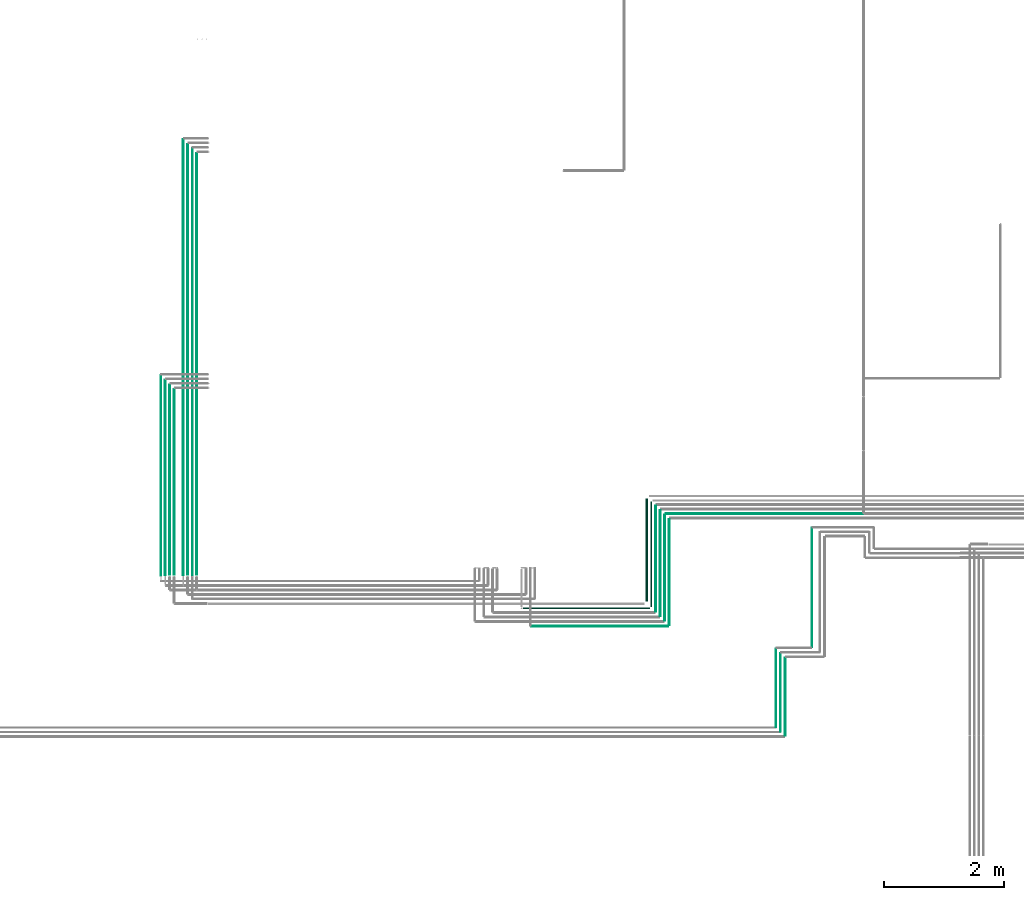
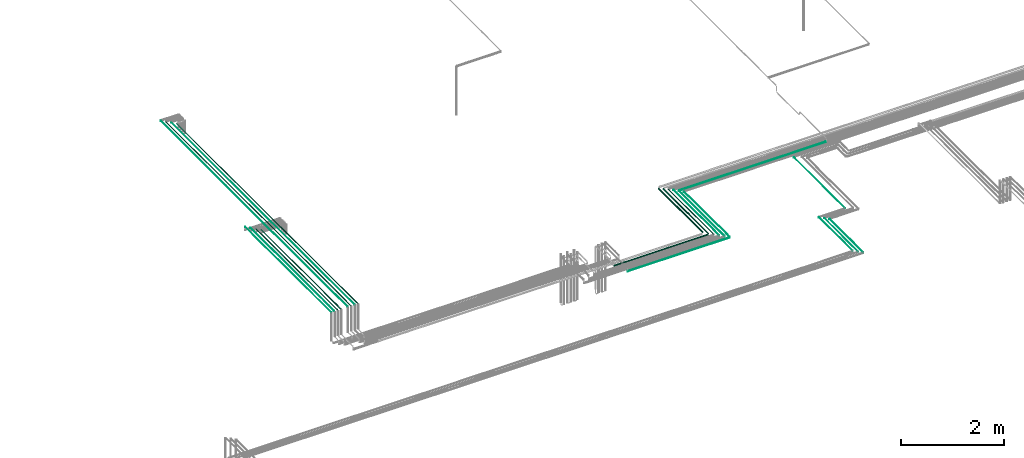
# One storey, part 5 of 65: 21 flow segments.
"""IFC2X3 building model written with IfcOpenShell, lengths in millimetres."""

import ifcopenshell
import ifcopenshell.guid

model = None  # the IFC model being written
_history = None  # IfcOwnerHistory: only IFC2X3 demands one
_inside = {}  # id of a spatial element -> (the spatial element, [elements in it])
_under = {}  # id of a project, library or spatial element -> (it, [spatial elements below it])
_declared = {}  # id of a project -> (the project, [libraries it declares])
_typed = {}  # id of a type object -> (the type object, [elements of that type])
_made_of = {}  # id of a material, layer set ... -> (it, [elements and type objects made of it])


def new_model(schema):
    """Start an empty IFC model of exactly this schema.

    Asked for "IFC4X3", IfcOpenShell would pick the latest addendum, in which some entities
    have other attributes; the version numbers below select the first issue.
    IFC2X3 requires an IfcOwnerHistory on every rooted entity: one is made here for all.
    """
    global model, _history
    if schema == "IFC4X3":
        model = ifcopenshell.file(schema_version=(4, 3, 0, 0))
    else:
        model = ifcopenshell.file(schema=schema)
    _inside.clear()
    _under.clear()
    _declared.clear()
    _typed.clear()
    _made_of.clear()
    _history = None
    if model.schema == "IFC2X3":
        org = make("IfcOrganization", Name="unknown")
        user = make(
            "IfcPersonAndOrganization",
            ThePerson=make("IfcPerson", FamilyName="unknown"),
            TheOrganization=org,
        )
        app = make(
            "IfcApplication",
            ApplicationDeveloper=org,
            Version="unknown",
            ApplicationFullName="unknown",
            ApplicationIdentifier="unknown",
        )
        _history = make(
            "IfcOwnerHistory",
            OwningUser=user,
            OwningApplication=app,
            ChangeAction="ADDED",
            CreationDate=0,
        )
    return model


def make(cls, **values):
    """One entity of the class cls with the attributes given. An attribute that is None is left unset."""
    return model.create_entity(
        cls, **{name: value for name, value in values.items() if value is not None}
    )


def entity(cls, *values):
    """Any entity or typed value of the class cls, its attributes in the order of the schema. None: left unset."""
    e = model.create_entity(cls)
    for i, value in enumerate(values):
        if value is not None:
            e[i] = value
    return e


def rooted(cls, **values):
    """An entity with a GlobalId (a new one), such as an element, a storey or a relation."""
    return make(cls, GlobalId=ifcopenshell.guid.new(), OwnerHistory=_history, **values)


def si_unit(unit_type, name, prefix=None):
    """IfcSIUnit, for example si_unit("LENGTHUNIT", "METRE", prefix="MILLI")."""
    return make("IfcSIUnit", UnitType=unit_type, Prefix=prefix, Name=name)


def converted_unit(unit_type, name, factor, base, dimensions=None, offset=None):
    """IfcConversionBasedUnit, such as the inch: factor (a typed value) times the base unit."""
    return make(
        "IfcConversionBasedUnit"
        if offset is None
        else "IfcConversionBasedUnitWithOffset",
        ConversionOffset=offset,
        Dimensions=None
        if dimensions is None
        else entity("IfcDimensionalExponents", *dimensions),
        UnitType=unit_type,
        Name=name,
        ConversionFactor=make(
            "IfcMeasureWithUnit", ValueComponent=factor, UnitComponent=base
        ),
    )


def derived_unit(unit_type, elements):
    """IfcDerivedUnit: a product of units, each with its exponent."""
    return make(
        "IfcDerivedUnit",
        Elements=[
            make("IfcDerivedUnitElement", Unit=unit, Exponent=power)
            for unit, power in elements
        ],
        UnitType=unit_type,
    )


def assignment(units):
    """IfcUnitAssignment: the units of a project."""
    return None if units is None else make("IfcUnitAssignment", Units=units)


def point(xyz):
    """IfcCartesianPoint."""
    return None if xyz is None else make("IfcCartesianPoint", Coordinates=xyz)


def direction(xyz):
    """IfcDirection."""
    return None if xyz is None else make("IfcDirection", DirectionRatios=xyz)


def frame(location, z_axis=None, x_axis=None):
    """IfcAxis2Placement3D, a coordinate frame: its origin and axes. An axis left out is left unset."""
    return make(
        "IfcAxis2Placement3D",
        Location=point(location),
        Axis=direction(z_axis),
        RefDirection=direction(x_axis),
    )


def frame_2d(location, x_axis=None):
    """IfcAxis2Placement2D, a coordinate frame in the plane: its origin and x axis."""
    return make(
        "IfcAxis2Placement2D", Location=point(location), RefDirection=direction(x_axis)
    )


def origin():
    """The frame at (0, 0, 0) with its axes left unset."""
    return frame((0.0, 0.0, 0.0))


def origin_2d_with_axis():
    """The frame at (0, 0) in the plane with the x axis (1, 0) written out."""
    return frame_2d((0.0, 0.0), x_axis=(1.0, 0.0))


def place(relative_to, where):
    """IfcLocalPlacement: puts the frame where relative to a parent placement (None: the world)."""
    return make(
        "IfcLocalPlacement", PlacementRelTo=relative_to, RelativePlacement=where
    )


def context(
    kind, dimensions, precision=None, world=None, true_north=None, identifier=None
):
    """IfcGeometricRepresentationContext, for example the 3D "Model" context."""
    return make(
        "IfcGeometricRepresentationContext",
        ContextIdentifier=identifier,
        ContextType=kind,
        CoordinateSpaceDimension=dimensions,
        Precision=precision,
        WorldCoordinateSystem=world,
        TrueNorth=true_north,
    )


def subcontext(parent, identifier, kind, view, scale=None):
    """IfcGeometricRepresentationSubContext, for example "Body" below "Model"."""
    return make(
        "IfcGeometricRepresentationSubContext",
        ContextIdentifier=identifier,
        ContextType=kind,
        ParentContext=parent,
        TargetScale=scale,
        TargetView=view,
    )


def project(units=None, contexts=None):
    """IfcProject with its units and contexts."""
    return rooted(
        "IfcProject",
        Name="project",
        RepresentationContexts=contexts,
        UnitsInContext=assignment(units),
    )


def spatial(cls, under=None, at=None, **own):
    """A site, building, storey or space (cls), placed at a placement, below another one or the project."""
    s = rooted(cls, ObjectPlacement=at, **own)
    if under is not None:
        _under.setdefault(under.id(), (under, []))[1].append(s)
    return s


def profile(cls, at=None, kind="AREA", **sizes):
    """A parametric profile (cls). Its sizes go by their IFC names, for example OverallWidth=200.0."""
    return make(cls, ProfileType=kind, Position=at, **sizes)


def circle(**sizes):
    """IfcCircleProfileDef."""
    return profile("IfcCircleProfileDef", **sizes)


def extrude(swept, where, along, depth):
    """IfcExtrudedAreaSolid: the profile swept, set in the frame where, extruded along a direction by depth."""
    return make(
        "IfcExtrudedAreaSolid",
        SweptArea=swept,
        Position=where,
        ExtrudedDirection=direction(along),
        Depth=depth,
    )


def shape(context_of_items, identifier, shape_type, items):
    """IfcShapeRepresentation: the items that make up one representation, for example the "Body"."""
    return make(
        "IfcShapeRepresentation",
        ContextOfItems=context_of_items,
        RepresentationIdentifier=identifier,
        RepresentationType=shape_type,
        Items=items,
    )


def made_of(thing, what):
    """Note that an element or type object is made of a material, layer set ...; save() writes the relation."""
    if what is not None:
        _made_of.setdefault(what.id(), (what, []))[1].append(thing)
    return thing


def type_object(cls, material=None, **own):
    """A type object (cls), such as IfcWallType, which elements share."""
    return made_of(rooted(cls, **own), material)


def element(
    cls,
    number,
    at=None,
    inside=None,
    cuts=None,
    type_object=None,
    material=None,
    context=None,
    identifier="Body",
    shape_type=None,
    held_by="IfcProductDefinitionShape",
    body=None,
    shapes=None,
    **own,
):
    """One element of the class cls, such as IfcWall. Its Tag is "e" and its number.

    at: its placement. inside: the storey or other place that contains it. cuts: it is an
    opening in that element (IfcRelVoidsElement). A single representation is given by context,
    identifier, shape_type and body (its items); several are given by shapes. held_by: the class
    of the entity that holds the representations. save() writes the other relations.
    """
    e = rooted(cls, Tag="e%d" % number, ObjectPlacement=at, **own)
    if body is not None:
        shapes = [shape(context, identifier, shape_type, body)]
    if shapes is not None:
        e.Representation = make(held_by, Representations=shapes)
    if inside is not None:
        _inside.setdefault(inside.id(), (inside, []))[1].append(e)
    if cuts is not None:
        rooted(
            "IfcRelVoidsElement", RelatingBuildingElement=cuts, RelatedOpeningElement=e
        )
    if type_object is not None:
        _typed.setdefault(type_object.id(), (type_object, []))[1].append(e)
    return made_of(e, material)


def aggregate(whole, parts):
    """IfcRelAggregates: a whole, such as a stair, and the parts it consists of."""
    return rooted("IfcRelAggregates", RelatingObject=whole, RelatedObjects=parts)


def save(model, path):
    """Write the relations noted so far, then the file.

    IfcRelAggregates (storeys below a building ...), IfcRelContainedInSpatialStructure (elements
    in a storey), IfcRelDefinesByType, IfcRelAssociatesMaterial and IfcRelDeclares: one each for
    every whole, place, type object, material and project.
    """
    for whole, parts in _under.values():
        aggregate(whole, parts)
    for where, things in _inside.values():
        rooted(
            "IfcRelContainedInSpatialStructure",
            RelatedElements=things,
            RelatingStructure=where,
        )
    for kind, things in _typed.values():
        rooted("IfcRelDefinesByType", RelatedObjects=things, RelatingType=kind)
    for what, things in _made_of.values():
        rooted("IfcRelAssociatesMaterial", RelatedObjects=things, RelatingMaterial=what)
    for by, libraries in _declared.values():
        rooted("IfcRelDeclares", RelatingContext=by, RelatedDefinitions=libraries)
    model.write(path)


model = new_model("IFC2X3")

# Units and contexts
model_context = context("Model", 3, precision=0.01, world=origin(), true_north=direction((6.12303176911189e-17, 1.0)))
body_context = subcontext(model_context, "Body", "Model", "MODEL_VIEW")
ifc_project = project(units=[si_unit("LENGTHUNIT", "METRE", prefix="MILLI"), si_unit("AREAUNIT", "SQUARE_METRE"), si_unit("VOLUMEUNIT", "CUBIC_METRE"), converted_unit("PLANEANGLEUNIT", "DEGREE", entity("IfcRatioMeasure", 0.0174532925199433), si_unit("PLANEANGLEUNIT", "RADIAN"), dimensions=[0, 0, 0, 0, 0, 0, 0]), si_unit("MASSUNIT", "GRAM", prefix="KILO"), derived_unit("MASSDENSITYUNIT", [(si_unit("MASSUNIT", "GRAM", prefix="KILO"), 1), (si_unit("LENGTHUNIT", "METRE"), -3)]), derived_unit("MOMENTOFINERTIAUNIT", [(si_unit("LENGTHUNIT", "METRE"), 4)]), si_unit("TIMEUNIT", "SECOND"), si_unit("FREQUENCYUNIT", "HERTZ"), si_unit("THERMODYNAMICTEMPERATUREUNIT", "DEGREE_CELSIUS"), derived_unit("THERMALTRANSMITTANCEUNIT", [(si_unit("MASSUNIT", "GRAM", prefix="KILO"), 1), (si_unit("THERMODYNAMICTEMPERATUREUNIT", "KELVIN"), -1), (si_unit("TIMEUNIT", "SECOND"), -3)]), derived_unit("VOLUMETRICFLOWRATEUNIT", [(si_unit("LENGTHUNIT", "METRE"), 3), (si_unit("TIMEUNIT", "SECOND"), -1)]), derived_unit("MASSFLOWRATEUNIT", [(si_unit("MASSUNIT", "GRAM", prefix="KILO"), 1), (si_unit("TIMEUNIT", "SECOND"), -1)]), derived_unit("ROTATIONALFREQUENCYUNIT", [(si_unit("TIMEUNIT", "SECOND"), -1)]), si_unit("ELECTRICCURRENTUNIT", "AMPERE"), si_unit("ELECTRICVOLTAGEUNIT", "VOLT"), si_unit("POWERUNIT", "WATT"), si_unit("FORCEUNIT", "NEWTON", prefix="KILO"), si_unit("ILLUMINANCEUNIT", "LUX"), si_unit("LUMINOUSFLUXUNIT", "LUMEN"), si_unit("LUMINOUSINTENSITYUNIT", "CANDELA"), derived_unit("USERDEFINED", [(si_unit("MASSUNIT", "GRAM", prefix="KILO"), -1), (si_unit("LENGTHUNIT", "METRE"), -2), (si_unit("TIMEUNIT", "SECOND"), 3), (si_unit("LUMINOUSFLUXUNIT", "LUMEN"), 1)]), derived_unit("LINEARVELOCITYUNIT", [(si_unit("LENGTHUNIT", "METRE"), 1), (si_unit("TIMEUNIT", "SECOND"), -1)]), si_unit("PRESSUREUNIT", "PASCAL"), derived_unit("USERDEFINED", [(si_unit("LENGTHUNIT", "METRE"), -2), (si_unit("MASSUNIT", "GRAM", prefix="KILO"), 1), (si_unit("TIMEUNIT", "SECOND"), -2)]), derived_unit("LINEARFORCEUNIT", [(si_unit("MASSUNIT", "GRAM", prefix="KILO"), 1), (si_unit("LENGTHUNIT", "METRE"), 1), (si_unit("TIMEUNIT", "SECOND"), -2), (si_unit("LENGTHUNIT", "METRE"), -1)]), derived_unit("PLANARFORCEUNIT", [(si_unit("MASSUNIT", "GRAM", prefix="KILO"), 1), (si_unit("LENGTHUNIT", "METRE"), 1), (si_unit("TIMEUNIT", "SECOND"), -2), (si_unit("LENGTHUNIT", "METRE"), -2)])], contexts=[model_context])

# Site, building, storey
site_placement = place(None, frame((0.0, -0.00077364408347762, 0.0)))
site = spatial("IfcSite", under=ifc_project, at=site_placement, CompositionType="ELEMENT")
building_placement = place(site_placement, origin())
building = spatial("IfcBuilding", under=site, at=building_placement, CompositionType="ELEMENT")
storey_placement = place(building_placement, frame((0.0, 0.0, 19800.0)))
storey = spatial("IfcBuildingStorey", under=building, at=storey_placement, CompositionType="ELEMENT", Elevation=19800.0)

# Flow segments
pipe_segment_type = type_object("IfcPipeSegmentType", PredefinedType="NOTDEFINED")
flow_segment_1_placement = place(storey_placement, frame((45451.0268664146, 6940.0, 2455.90472776409)))
element("IfcFlowSegment", 1, at=flow_segment_1_placement, inside=storey, type_object=pipe_segment_type, context=body_context, shape_type="SweptSolid", body=[
    extrude(circle(Radius=17.5, at=frame_2d((8.66293703438714e-12, 0.0), x_axis=(1.0, 0.0))), frame((19.0952722359206, 0.0, 19.0952722359163), z_axis=(0.0, 1.0, 0.0), x_axis=(-1.0, 0.0, 0.0)), (0.0, 0.0, 1.0), 1720.0002059937),
])
flow_segment_2_placement = place(storey_placement, frame((45532.5268664146, 6849.0, 2462.40472776408)))
element("IfcFlowSegment", 2, at=flow_segment_2_placement, inside=storey, type_object=pipe_segment_type, context=body_context, shape_type="SweptSolid", body=[
    extrude(circle(Radius=11.0, at=origin_2d_with_axis()), frame((12.5952722359047, 0.0, 12.5952722359177), z_axis=(0.0, 1.0, 0.0), x_axis=(-1.0, 0.0, 0.0)), (0.0, 0.0, 1.0), 1752.00020599373),
])
flow_segment_3_placement = place(storey_placement, frame((43406.2717944076, 6812.40472776403, 2462.40472776408)))
element("IfcFlowSegment", 3, at=flow_segment_3_placement, inside=storey, type_object=pipe_segment_type, context=body_context, shape_type="SweptSolid", body=[
    extrude(circle(Radius=11.0, at=frame_2d((-8.66293703438714e-12, 0.0), x_axis=(1.0, 0.0))), frame((0.0, 12.5952722359242, 12.5952722359177), z_axis=(1.0, 0.0, 0.0), x_axis=(0.0, 1.0, 0.0)), (0.0, 0.0, 1.0), 2114.85034424296),
])
flow_segment_4_placement = place(storey_placement, frame((45611.0268664146, 6768.0, 2465.90472776409)))
element("IfcFlowSegment", 4, at=flow_segment_4_placement, inside=storey, type_object=pipe_segment_type, context=body_context, shape_type="SweptSolid", body=[
    extrude(circle(Radius=7.5, at=origin_2d_with_axis()), frame((9.09527223593152, 0.0, 9.09527223591419), z_axis=(0.0, 1.0, 0.0), x_axis=(1.0, 0.0, 0.0)), (0.0, 0.0, 1.0), 1764.00020599378),
])
flow_segment_5_placement = place(storey_placement, frame((45687.5268664146, 6689.0, 2467.40472776409)))
element("IfcFlowSegment", 5, at=flow_segment_5_placement, inside=storey, type_object=pipe_segment_type, context=body_context, shape_type="SweptSolid", body=[
    extrude(circle(Radius=6.0, at=origin_2d_with_axis()), frame((7.59527223593186, 0.0, 7.59527223591454), z_axis=(0.0, 1.0, 0.0), x_axis=(1.0, 0.0, 0.0)), (0.0, 0.0, 1.0), 1772.00020599377),
])
flow_segment_6_placement = place(storey_placement, frame((45837.5268664146, 6539.0, 2467.40472776409)))
element("IfcFlowSegment", 6, at=flow_segment_6_placement, inside=storey, type_object=pipe_segment_type, context=body_context, shape_type="SweptSolid", body=[
    extrude(circle(Radius=6.0, at=origin_2d_with_axis()), frame((7.59527223593186, 0.0, 7.59527223591454), z_axis=(0.0, 1.0, 0.0), x_axis=(1.0, 0.0, 0.0)), (0.0, 0.0, 1.0), 1772.00020599378),
])
flow_segment_7_placement = place(storey_placement, frame((43546.2717944076, 6517.40472776402, 2467.40472776409)))
element("IfcFlowSegment", 7, at=flow_segment_7_placement, inside=storey, type_object=pipe_segment_type, context=body_context, shape_type="SweptSolid", body=[
    extrude(circle(Radius=6.0, at=frame_2d((-1.62430069394759e-11, 0.0), x_axis=(1.0, 0.0))), frame((0.0, 7.59527223593186, 7.59527223591454), z_axis=(1.0, 0.0, 0.0), x_axis=(0.0, 1.0, 0.0)), (0.0, 0.0, 1.0), 2284.85034424298),
])
flow_segment_8_placement = place(storey_placement, frame((45762.5268664146, 6614.0, 2467.40472776409)))
element("IfcFlowSegment", 8, at=flow_segment_8_placement, inside=storey, type_object=pipe_segment_type, context=body_context, shape_type="SweptSolid", body=[
    extrude(circle(Radius=6.0, at=origin_2d_with_axis()), frame((7.59527223594919, 0.0, 7.59527223591454), z_axis=(0.0, 1.0, 0.0), x_axis=(1.0, 0.0, 0.0)), (0.0, 0.0, 1.0), 1772.00020599378),
])
flow_segment_9_placement = place(storey_placement, frame((48220.123695365, 6170.0, 2544.40472776409)))
element("IfcFlowSegment", 9, at=flow_segment_9_placement, inside=storey, type_object=pipe_segment_type, context=body_context, shape_type="SweptSolid", body=[
    extrude(circle(Radius=4.0, at=frame_2d((1.12618181447033e-10, 0.0), x_axis=(1.0, 0.0))), frame((5.59527223602761, 0.0, 5.59527223591499), z_axis=(0.0, 1.0, 0.0), x_axis=(-1.0, 0.0, 0.0)), (0.0, 0.0, 1.0), 1995.00020599365),
])
flow_segment_10_placement = place(storey_placement, frame((47773.2310461019, 4694.0, 2542.40472776409)))
element("IfcFlowSegment", 10, at=flow_segment_10_placement, inside=storey, type_object=pipe_segment_type, context=body_context, shape_type="SweptSolid", body=[
    extrude(circle(Radius=6.0, at=frame_2d((1.73258740687743e-11, 0.0), x_axis=(1.0, 0.0))), frame((7.59527223593186, 0.0, 7.59527223591454), z_axis=(0.0, 1.0, 0.0), x_axis=(-1.0, 0.0, 0.0)), (0.0, 0.0, 1.0), 1302.00000000006),
])
flow_segment_11_placement = place(storey_placement, frame((47700.2310461019, 4765.0, 2544.40472776409)))
element("IfcFlowSegment", 11, at=flow_segment_11_placement, inside=storey, type_object=pipe_segment_type, context=body_context, shape_type="SweptSolid", body=[
    extrude(circle(Radius=4.0, at=frame_2d((1.03955244412646e-10, 0.0), x_axis=(1.0, 0.0))), frame((5.59527223601895, 0.0, 5.59527223591499), z_axis=(0.0, 1.0, 0.0), x_axis=(-1.0, 0.0, 0.0)), (0.0, 0.0, 1.0), 1310.00000000006),
])
flow_segment_12_placement = place(storey_placement, frame((47625.2310461019, 4840.0, 2544.40472776409)))
element("IfcFlowSegment", 12, at=flow_segment_12_placement, inside=storey, type_object=pipe_segment_type, context=body_context, shape_type="SweptSolid", body=[
    extrude(circle(Radius=4.0, at=frame_2d((7.79664333094843e-11, 0.0), x_axis=(1.0, 0.0))), frame((5.59527223599296, 0.0, 5.59527223591499), z_axis=(0.0, 1.0, 0.0), x_axis=(-1.0, 0.0, 0.0)), (0.0, 0.0, 1.0), 1310.00000000006),
])
flow_segment_13_placement = place(storey_placement, frame((37355.2088804252, 7365.0, 3144.4047277641)))
element("IfcFlowSegment", 13, at=flow_segment_13_placement, inside=storey, type_object=pipe_segment_type, context=body_context, shape_type="SweptSolid", body=[
    extrude(circle(Radius=4.0, at=origin_2d_with_axis()), frame((5.59527223591499, 0.0, 5.59527223591499), z_axis=(0.0, 1.0, 0.0), x_axis=(-1.0, 0.0, 0.0)), (0.0, 0.0, 1.0), 3349.68656489794),
])
flow_segment_14_placement = place(storey_placement, frame((37428.2088804252, 7378.0, 3142.40472776409)))
element("IfcFlowSegment", 14, at=flow_segment_14_placement, inside=storey, type_object=pipe_segment_type, context=body_context, shape_type="SweptSolid", body=[
    extrude(circle(Radius=6.0, at=origin_2d_with_axis()), frame((7.59527223591454, 0.0, 7.59527223591454), z_axis=(0.0, 1.0, 0.0), x_axis=(-1.0, 0.0, 0.0)), (0.0, 0.0, 1.0), 3257.68656489791),
])
flow_segment_15_placement = place(storey_placement, frame((37501.7088804252, 7384.0, 3140.90472776409)))
element("IfcFlowSegment", 15, at=flow_segment_15_placement, inside=storey, type_object=pipe_segment_type, context=body_context, shape_type="SweptSolid", body=[
    extrude(circle(Radius=7.5, at=origin_2d_with_axis()), frame((9.09527223591419, 0.0, 9.09527223591419), z_axis=(0.0, 1.0, 0.0), x_axis=(-1.0, 0.0, 0.0)), (0.0, 0.0, 1.0), 3172.6865648979),
])
flow_segment_16_placement = place(storey_placement, frame((37576.7088804252, 7384.0, 3140.90472776409)))
element("IfcFlowSegment", 16, at=flow_segment_16_placement, inside=storey, type_object=pipe_segment_type, context=body_context, shape_type="SweptSolid", body=[
    extrude(circle(Radius=7.5, at=origin_2d_with_axis()), frame((9.09527223591419, 0.0, 9.09527223591419), z_axis=(0.0, 1.0, 0.0), x_axis=(-1.0, 0.0, 0.0)), (0.0, 0.0, 1.0), 3097.68656489789),
])
flow_segment_17_placement = place(storey_placement, frame((37728.2088804252, 7378.0, 3142.40472776401)))
element("IfcFlowSegment", 17, at=flow_segment_17_placement, inside=storey, type_object=pipe_segment_type, context=body_context, shape_type="SweptSolid", body=[
    extrude(circle(Radius=6.0, at=frame_2d((4.33146851719357e-12, 0.0), x_axis=(1.0, 0.0))), frame((7.59527223591887, 0.0, 7.59527223591454), z_axis=(0.0, 1.0, 0.0), x_axis=(-1.0, 0.0, 0.0)), (0.0, 0.0, 1.0), 7272.6865648979),
])
flow_segment_18_placement = place(storey_placement, frame((37801.7088804252, 7384.0, 3140.90472776401)))
element("IfcFlowSegment", 18, at=flow_segment_18_placement, inside=storey, type_object=pipe_segment_type, context=body_context, shape_type="SweptSolid", body=[
    extrude(circle(Radius=7.5, at=frame_2d((4.33146851719357e-12, 0.0), x_axis=(1.0, 0.0))), frame((9.09527223591853, 0.0, 9.09527223591419), z_axis=(0.0, 1.0, 0.0), x_axis=(-1.0, 0.0, 0.0)), (0.0, 0.0, 1.0), 7187.68656489789),
])
flow_segment_19_placement = place(storey_placement, frame((37880.2088804252, 7372.0, 3144.40472776402)))
element("IfcFlowSegment", 19, at=flow_segment_19_placement, inside=storey, type_object=pipe_segment_type, context=body_context, shape_type="SweptSolid", body=[
    extrude(circle(Radius=4.0, at=frame_2d((4.33146851719357e-12, 0.0), x_axis=(1.0, 0.0))), frame((5.59527223591932, 0.0, 5.59527223591499), z_axis=(0.0, 1.0, 0.0), x_axis=(-1.0, 0.0, 0.0)), (0.0, 0.0, 1.0), 7132.68656489789),
])
flow_segment_20_placement = place(storey_placement, frame((37951.7088804252, 7384.0, 3140.90472776401)))
element("IfcFlowSegment", 20, at=flow_segment_20_placement, inside=storey, type_object=pipe_segment_type, context=body_context, shape_type="SweptSolid", body=[
    extrude(circle(Radius=7.5, at=frame_2d((8.66293703438714e-12, 0.0), x_axis=(1.0, 0.0))), frame((9.09527223592286, 0.0, 9.09527223591419), z_axis=(0.0, 1.0, 0.0), x_axis=(-1.0, 0.0, 0.0)), (0.0, 0.0, 1.0), 7037.68656489788),
])
flow_segment_21_placement = place(storey_placement, frame((45790.1221386505, 8390.90493375772, 2465.90472776414)))
element("IfcFlowSegment", 21, at=flow_segment_21_placement, inside=storey, type_object=pipe_segment_type, context=body_context, shape_type="SweptSolid", body=[
    extrude(circle(Radius=7.5, at=frame_2d((-3.5734615266847e-11, 0.0), x_axis=(1.0, 0.0))), frame((0.0, 9.09527223595318, 9.09527223591419), z_axis=(1.0, 0.0, 0.0), x_axis=(0.0, 1.0, 0.0)), (0.0, 0.0, 1.0), 3296.87643312682),
])

save(model, "model.ifc")
